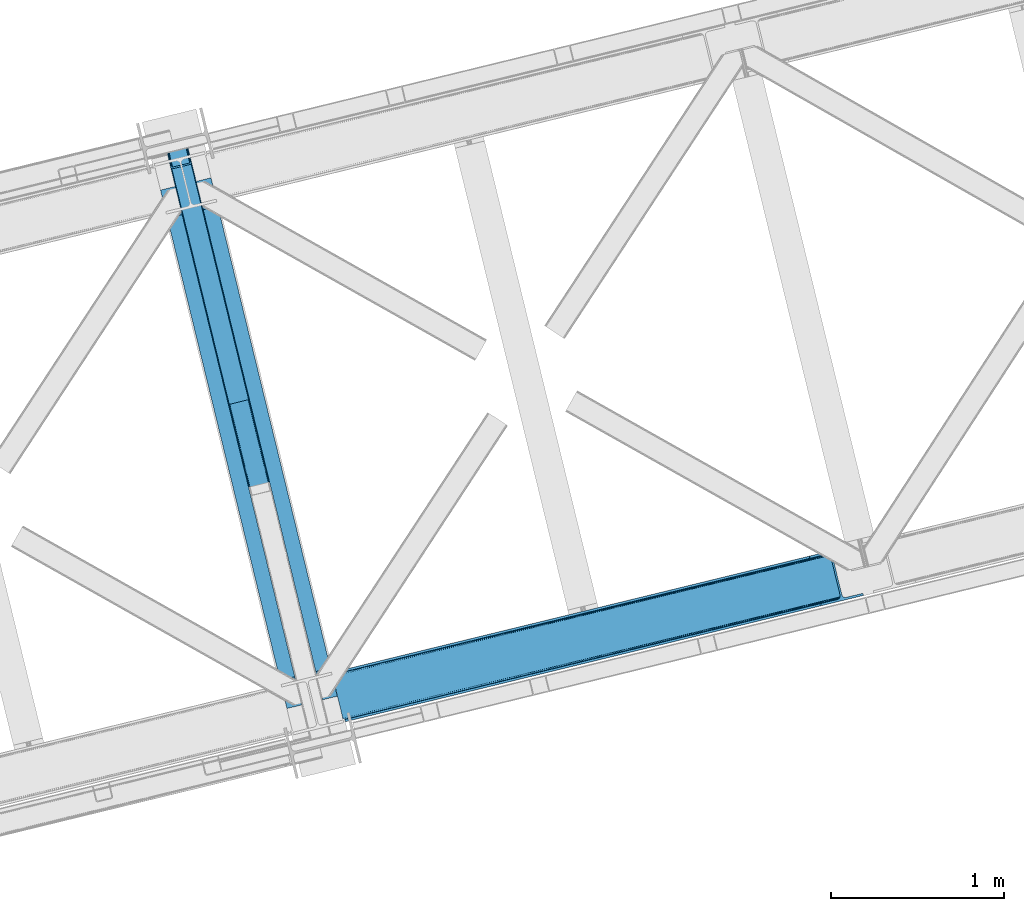
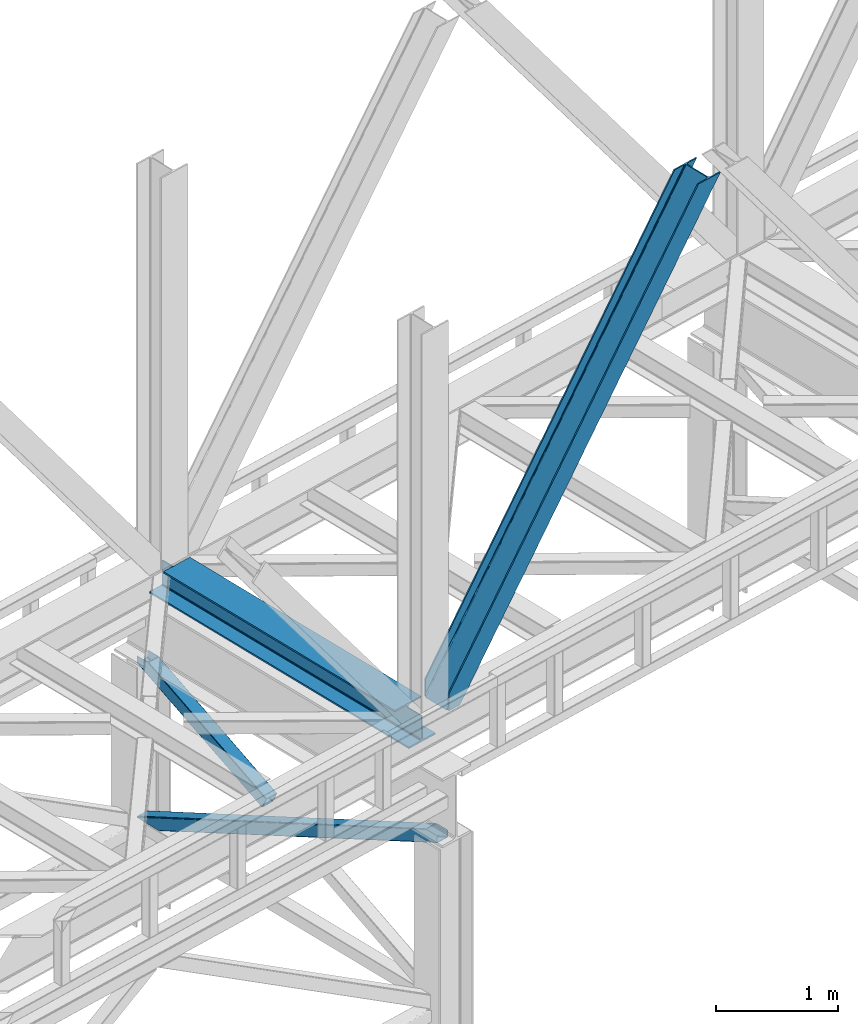
# One storey, part 51 of 93: 3 members, 1 beam.
"""IFC4 building model written with IfcOpenShell, lengths in millimetres."""

import ifcopenshell
import ifcopenshell.guid

model = None  # the IFC model being written
_history = None  # IfcOwnerHistory: only IFC2X3 demands one
_inside = {}  # id of a spatial element -> (the spatial element, [elements in it])
_under = {}  # id of a project, library or spatial element -> (it, [spatial elements below it])
_declared = {}  # id of a project -> (the project, [libraries it declares])
_typed = {}  # id of a type object -> (the type object, [elements of that type])
_made_of = {}  # id of a material, layer set ... -> (it, [elements and type objects made of it])


def new_model(schema):
    """Start an empty IFC model of exactly this schema.

    Asked for "IFC4X3", IfcOpenShell would pick the latest addendum, in which some entities
    have other attributes; the version numbers below select the first issue.
    IFC2X3 requires an IfcOwnerHistory on every rooted entity: one is made here for all.
    """
    global model, _history
    if schema == "IFC4X3":
        model = ifcopenshell.file(schema_version=(4, 3, 0, 0))
    else:
        model = ifcopenshell.file(schema=schema)
    _inside.clear()
    _under.clear()
    _declared.clear()
    _typed.clear()
    _made_of.clear()
    _history = None
    if model.schema == "IFC2X3":
        org = make("IfcOrganization", Name="unknown")
        user = make(
            "IfcPersonAndOrganization",
            ThePerson=make("IfcPerson", FamilyName="unknown"),
            TheOrganization=org,
        )
        app = make(
            "IfcApplication",
            ApplicationDeveloper=org,
            Version="unknown",
            ApplicationFullName="unknown",
            ApplicationIdentifier="unknown",
        )
        _history = make(
            "IfcOwnerHistory",
            OwningUser=user,
            OwningApplication=app,
            ChangeAction="ADDED",
            CreationDate=0,
        )
    return model


def make(cls, **values):
    """One entity of the class cls with the attributes given. An attribute that is None is left unset."""
    return model.create_entity(
        cls, **{name: value for name, value in values.items() if value is not None}
    )


def entity(cls, *values):
    """Any entity or typed value of the class cls, its attributes in the order of the schema. None: left unset."""
    e = model.create_entity(cls)
    for i, value in enumerate(values):
        if value is not None:
            e[i] = value
    return e


def rooted(cls, **values):
    """An entity with a GlobalId (a new one), such as an element, a storey or a relation."""
    return make(cls, GlobalId=ifcopenshell.guid.new(), OwnerHistory=_history, **values)


def si_unit(unit_type, name, prefix=None):
    """IfcSIUnit, for example si_unit("LENGTHUNIT", "METRE", prefix="MILLI")."""
    return make("IfcSIUnit", UnitType=unit_type, Prefix=prefix, Name=name)


def converted_unit(unit_type, name, factor, base, dimensions=None, offset=None):
    """IfcConversionBasedUnit, such as the inch: factor (a typed value) times the base unit."""
    return make(
        "IfcConversionBasedUnit"
        if offset is None
        else "IfcConversionBasedUnitWithOffset",
        ConversionOffset=offset,
        Dimensions=None
        if dimensions is None
        else entity("IfcDimensionalExponents", *dimensions),
        UnitType=unit_type,
        Name=name,
        ConversionFactor=make(
            "IfcMeasureWithUnit", ValueComponent=factor, UnitComponent=base
        ),
    )


def derived_unit(unit_type, elements):
    """IfcDerivedUnit: a product of units, each with its exponent."""
    return make(
        "IfcDerivedUnit",
        Elements=[
            make("IfcDerivedUnitElement", Unit=unit, Exponent=power)
            for unit, power in elements
        ],
        UnitType=unit_type,
    )


def assignment(units):
    """IfcUnitAssignment: the units of a project."""
    return None if units is None else make("IfcUnitAssignment", Units=units)


def point(xyz):
    """IfcCartesianPoint."""
    return None if xyz is None else make("IfcCartesianPoint", Coordinates=xyz)


def direction(xyz):
    """IfcDirection."""
    return None if xyz is None else make("IfcDirection", DirectionRatios=xyz)


def frame(location, z_axis=None, x_axis=None):
    """IfcAxis2Placement3D, a coordinate frame: its origin and axes. An axis left out is left unset."""
    return make(
        "IfcAxis2Placement3D",
        Location=point(location),
        Axis=direction(z_axis),
        RefDirection=direction(x_axis),
    )


def origin():
    """The frame at (0, 0, 0) with its axes left unset."""
    return frame((0.0, 0.0, 0.0))


def place(relative_to, where):
    """IfcLocalPlacement: puts the frame where relative to a parent placement (None: the world)."""
    return make(
        "IfcLocalPlacement", PlacementRelTo=relative_to, RelativePlacement=where
    )


def context(
    kind, dimensions, precision=None, world=None, true_north=None, identifier=None
):
    """IfcGeometricRepresentationContext, for example the 3D "Model" context."""
    return make(
        "IfcGeometricRepresentationContext",
        ContextIdentifier=identifier,
        ContextType=kind,
        CoordinateSpaceDimension=dimensions,
        Precision=precision,
        WorldCoordinateSystem=world,
        TrueNorth=true_north,
    )


def subcontext(parent, identifier, kind, view, scale=None):
    """IfcGeometricRepresentationSubContext, for example "Body" below "Model"."""
    return make(
        "IfcGeometricRepresentationSubContext",
        ContextIdentifier=identifier,
        ContextType=kind,
        ParentContext=parent,
        TargetScale=scale,
        TargetView=view,
    )


def project(units=None, contexts=None):
    """IfcProject with its units and contexts."""
    return rooted(
        "IfcProject",
        Name="project",
        RepresentationContexts=contexts,
        UnitsInContext=assignment(units),
    )


def spatial(cls, under=None, at=None, **own):
    """A site, building, storey or space (cls), placed at a placement, below another one or the project."""
    s = rooted(cls, ObjectPlacement=at, **own)
    if under is not None:
        _under.setdefault(under.id(), (under, []))[1].append(s)
    return s


def point_list(points):
    """IfcCartesianPointList2D or 3D."""
    cls = (
        "IfcCartesianPointList2D" if len(points[0]) == 2 else "IfcCartesianPointList3D"
    )
    return make(cls, CoordList=points)


def triangles(points, corners, closed=None, point_numbers=None):
    """IfcTriangulatedFaceSet: each triangle names its three corners, points numbered from 1."""
    return make(
        "IfcTriangulatedFaceSet",
        Coordinates=point_list(points),
        Closed=closed,
        CoordIndex=corners,
        PnIndex=point_numbers,
    )


def polygons(points, faces, closed=None, point_numbers=None):
    """IfcPolygonalFaceSet: a face is its outer loop, then its inner loops; points numbered from 1."""
    made = []
    for loops in faces:
        if len(loops) == 1:
            made.append(make("IfcIndexedPolygonalFace", CoordIndex=loops[0]))
        else:
            made.append(
                make(
                    "IfcIndexedPolygonalFaceWithVoids",
                    CoordIndex=loops[0],
                    InnerCoordIndices=loops[1:],
                )
            )
    return make(
        "IfcPolygonalFaceSet",
        Coordinates=point_list(points),
        Closed=closed,
        Faces=made,
        PnIndex=point_numbers,
    )


def shape(context_of_items, identifier, shape_type, items):
    """IfcShapeRepresentation: the items that make up one representation, for example the "Body"."""
    return make(
        "IfcShapeRepresentation",
        ContextOfItems=context_of_items,
        RepresentationIdentifier=identifier,
        RepresentationType=shape_type,
        Items=items,
    )


def material(Name=None, Category=None):
    """IfcMaterial."""
    return make("IfcMaterial", Name=Name, Category=Category)


def made_of(thing, what):
    """Note that an element or type object is made of a material, layer set ...; save() writes the relation."""
    if what is not None:
        _made_of.setdefault(what.id(), (what, []))[1].append(thing)
    return thing


def type_object(cls, material=None, **own):
    """A type object (cls), such as IfcWallType, which elements share."""
    return made_of(rooted(cls, **own), material)


def element(
    cls,
    number,
    at=None,
    inside=None,
    cuts=None,
    type_object=None,
    material=None,
    context=None,
    identifier="Body",
    shape_type=None,
    held_by="IfcProductDefinitionShape",
    body=None,
    shapes=None,
    **own,
):
    """One element of the class cls, such as IfcWall. Its Tag is "e" and its number.

    at: its placement. inside: the storey or other place that contains it. cuts: it is an
    opening in that element (IfcRelVoidsElement). A single representation is given by context,
    identifier, shape_type and body (its items); several are given by shapes. held_by: the class
    of the entity that holds the representations. save() writes the other relations.
    """
    e = rooted(cls, Tag="e%d" % number, ObjectPlacement=at, **own)
    if body is not None:
        shapes = [shape(context, identifier, shape_type, body)]
    if shapes is not None:
        e.Representation = make(held_by, Representations=shapes)
    if inside is not None:
        _inside.setdefault(inside.id(), (inside, []))[1].append(e)
    if cuts is not None:
        rooted(
            "IfcRelVoidsElement", RelatingBuildingElement=cuts, RelatedOpeningElement=e
        )
    if type_object is not None:
        _typed.setdefault(type_object.id(), (type_object, []))[1].append(e)
    return made_of(e, material)


def aggregate(whole, parts):
    """IfcRelAggregates: a whole, such as a stair, and the parts it consists of."""
    return rooted("IfcRelAggregates", RelatingObject=whole, RelatedObjects=parts)


def save(model, path):
    """Write the relations noted so far, then the file.

    IfcRelAggregates (storeys below a building ...), IfcRelContainedInSpatialStructure (elements
    in a storey), IfcRelDefinesByType, IfcRelAssociatesMaterial and IfcRelDeclares: one each for
    every whole, place, type object, material and project.
    """
    for whole, parts in _under.values():
        aggregate(whole, parts)
    for where, things in _inside.values():
        rooted(
            "IfcRelContainedInSpatialStructure",
            RelatedElements=things,
            RelatingStructure=where,
        )
    for kind, things in _typed.values():
        rooted("IfcRelDefinesByType", RelatedObjects=things, RelatingType=kind)
    for what, things in _made_of.values():
        rooted("IfcRelAssociatesMaterial", RelatedObjects=things, RelatingMaterial=what)
    for by, libraries in _declared.values():
        rooted("IfcRelDeclares", RelatingContext=by, RelatedDefinitions=libraries)
    model.write(path)


model = new_model("IFC4")

# Units and contexts
model_context = context("Model", 3, precision=0.01, world=origin(), true_north=direction((6.12303176911189e-17, 1.0)))
plan_context = context("Plan", 3, precision=0.01, world=origin(), true_north=direction((6.12303176911189e-17, 1.0)))
body_context = subcontext(model_context, "Body", "Model", "MODEL_VIEW")
ifc_project = project(units=[si_unit("LENGTHUNIT", "METRE", prefix="MILLI"), si_unit("AREAUNIT", "SQUARE_METRE"), si_unit("VOLUMEUNIT", "CUBIC_METRE"), converted_unit("PLANEANGLEUNIT", "DEGREE", entity("IfcRatioMeasure", 0.0174532925199433), si_unit("PLANEANGLEUNIT", "RADIAN"), dimensions=[0, 0, 0, 0, 0, 0, 0]), si_unit("MASSUNIT", "GRAM", prefix="KILO"), derived_unit("MASSDENSITYUNIT", [(si_unit("MASSUNIT", "GRAM", prefix="KILO"), 1), (si_unit("LENGTHUNIT", "METRE"), -3)]), derived_unit("MOMENTOFINERTIAUNIT", [(si_unit("LENGTHUNIT", "METRE"), 4)]), si_unit("TIMEUNIT", "SECOND"), si_unit("FREQUENCYUNIT", "HERTZ"), si_unit("THERMODYNAMICTEMPERATUREUNIT", "DEGREE_CELSIUS"), derived_unit("THERMALTRANSMITTANCEUNIT", [(si_unit("MASSUNIT", "GRAM", prefix="KILO"), 1), (si_unit("THERMODYNAMICTEMPERATUREUNIT", "KELVIN"), -1), (si_unit("TIMEUNIT", "SECOND"), -3)]), derived_unit("VOLUMETRICFLOWRATEUNIT", [(si_unit("LENGTHUNIT", "METRE"), 3), (si_unit("TIMEUNIT", "SECOND"), -1)]), derived_unit("MASSFLOWRATEUNIT", [(si_unit("MASSUNIT", "GRAM", prefix="KILO"), 1), (si_unit("TIMEUNIT", "SECOND"), -1)]), derived_unit("ROTATIONALFREQUENCYUNIT", [(si_unit("TIMEUNIT", "SECOND"), -1)]), si_unit("ELECTRICCURRENTUNIT", "AMPERE"), si_unit("ELECTRICVOLTAGEUNIT", "VOLT"), si_unit("POWERUNIT", "WATT"), si_unit("FORCEUNIT", "NEWTON", prefix="KILO"), si_unit("ILLUMINANCEUNIT", "LUX"), si_unit("LUMINOUSFLUXUNIT", "LUMEN"), si_unit("LUMINOUSINTENSITYUNIT", "CANDELA"), derived_unit("USERDEFINED", [(si_unit("MASSUNIT", "GRAM", prefix="KILO"), -1), (si_unit("LENGTHUNIT", "METRE"), -2), (si_unit("TIMEUNIT", "SECOND"), 3), (si_unit("LUMINOUSFLUXUNIT", "LUMEN"), 1)]), derived_unit("LINEARVELOCITYUNIT", [(si_unit("LENGTHUNIT", "METRE"), 1), (si_unit("TIMEUNIT", "SECOND"), -1)]), si_unit("PRESSUREUNIT", "PASCAL"), derived_unit("USERDEFINED", [(si_unit("LENGTHUNIT", "METRE"), -2), (si_unit("MASSUNIT", "GRAM", prefix="KILO"), 1), (si_unit("TIMEUNIT", "SECOND"), -2)]), derived_unit("LINEARFORCEUNIT", [(si_unit("MASSUNIT", "GRAM", prefix="KILO"), 1), (si_unit("LENGTHUNIT", "METRE"), 1), (si_unit("TIMEUNIT", "SECOND"), -2), (si_unit("LENGTHUNIT", "METRE"), -1)]), derived_unit("PLANARFORCEUNIT", [(si_unit("MASSUNIT", "GRAM", prefix="KILO"), 1), (si_unit("LENGTHUNIT", "METRE"), 1), (si_unit("TIMEUNIT", "SECOND"), -2), (si_unit("LENGTHUNIT", "METRE"), -2)])], contexts=[model_context, plan_context])

# Site, building, storey
site_placement = place(None, origin())
site = spatial("IfcSite", under=ifc_project, at=site_placement, CompositionType="ELEMENT")
building_placement = place(site_placement, origin())
building = spatial("IfcBuilding", under=site, at=building_placement, CompositionType="ELEMENT")
storey_placement = place(building_placement, frame((0.0, 0.0, 15900.0)))
storey = spatial("IfcBuildingStorey", under=building, at=storey_placement, CompositionType="ELEMENT", Elevation=15900.0)

# Beam
ifc_material = material(Name="Metal painted (White)")
beam_type = type_object("IfcBeamType", PredefinedType="BEAM")
beam_placement = place(storey_placement, frame((-36670.8270654766, 8847.80273700045, 3385.0)))
element("IfcBeam", 1, at=beam_placement, inside=storey, type_object=beam_type, material=ifc_material, ObjectType="Steel Beam", PredefinedType="BEAM", context=body_context, shape_type="Tessellation", body=[
    polygons([(1022.42935345712, 71.0478278971032, 15.4999999999986), (1022.42935345712, 71.047827897101, 0.0), (291.465617442442, 3069.74325535076, 0.0), (291.465617442442, 3069.74325535076, 15.4999999999986), (899.042242073157, 40.970914087328, 15.4999999999986), (168.078506058478, 3039.66634154099, 15.4999999999986), (892.349898299203, 39.3395844888254, 16.8701684147963), (161.386162284524, 3038.03501194248, 16.8701684147963), (886.676403198579, 37.9566100336519, 20.7720779386413), (155.7126671839, 3036.65203748731, 20.7720779386413), (882.88549497, 37.0325360459162, 26.6116982174294), (151.921758955325, 3035.72796349958, 26.6116982174294), (881.554305026607, 36.7080444135029, 33.500000000001), (150.590569011932, 3035.40347186716, 33.500000000001), (140.875048430518, 3033.03521093726, 33.500000000001), (140.875048430518, 3033.03521093726, 259.000000000002), (150.590569011932, 3035.40347186716, 259.000000000002), (4.33146851719357e-12, 2998.69542745366, 0.0), (4.33146851719357e-12, 2998.69542745366, 15.4999999999986), (123.387111383964, 3028.77234126343, 15.4999999999986), (130.079455157922, 3030.40367086194, 16.8701684147963), (135.752950258542, 3031.78664531711, 20.7720779386413), (139.543858487117, 3032.71071930484, 26.6116982174294), (881.554305026612, 36.7080444135018, 259.000000000002), (871.838784445197, 34.3397834835992, 259.000000000002), (871.838784445197, 34.3397834835981, 33.500000000001), (870.507594501796, 34.0152918511827, 26.6116982174294), (866.716686273221, 33.0912178634492, 20.7720779386413), (861.043191172601, 31.7082434082767, 16.8701684147963), (854.350847398639, 30.0769138097708, 15.4999999999986), (730.963736014684, 1.08286712929839e-12, 15.4999999999986), (730.963736014675, 1.08286712929839e-12, 0.0), (841.854534586248, 199.571930111232, 259.069791776412), (190.199733064572, 2872.911390143, 259.000000000002), (190.423126166417, 2871.99494573803, 259.61730333112), (190.435515010051, 2871.94412150426, 266.500003008253), (841.709355772749, 200.167408132524, 266.500002998871), (841.709705893497, 200.16597182779, 260.000004007589), (832.229597305449, 196.831858094286, 259.006343172366), (832.006227290708, 197.748309612731, 259.61730333112), (831.993838447078, 197.799133846506, 266.500003008253), (180.719997684385, 2869.57584721824, 266.500002998871), (180.719647563629, 2869.57728352297, 260.000004007589), (180.574841905293, 2870.17133233676, 259.07612046749), (180.484212483149, 2870.5431292131, 259.000000000002), (843.040843642663, 200.490677577209, 273.388305639783), (846.831120231363, 201.417342749122, 279.227924098781), (852.504191178897, 202.8020572128, 283.129832400619), (859.196382860031, 204.434010743613, 284.500000377228), (982.583411547866, 234.511263798723, 284.500000138971), (982.581741741215, 234.518113867454, 299.999995328161), (691.116319643944, 163.469484603412, 299.999995890962), (691.117989450605, 163.462634534681, 284.500000701776), (814.50501813844, 193.539887589791, 284.500000463519), (821.197505034579, 195.170630056369, 283.129832461069), (826.871416683348, 196.551895700895, 279.227924137322), (830.662951470335, 197.473399350192, 273.388305663684), (179.388509814454, 2869.25257777355, 273.388305639783), (175.598233225758, 2868.32591260164, 279.227924098781), (169.925162278228, 2866.94119813796, 283.129832400619), (163.232970597094, 2865.30924460715, 284.500000377228), (39.8459419092591, 2835.23199155204, 284.500000138971), (39.8476117159108, 2835.22514148331, 299.999995328161), (331.313033813177, 2906.27377074735, 299.999995890962), (331.311364006521, 2906.28062081608, 284.500000701776), (207.924335318677, 2876.20336776097, 284.500000463519), (201.231848422542, 2874.57262529439, 283.129832461069), (195.557936773782, 2873.19135964986, 279.227924137322), (191.766401986782, 2872.26985600057, 273.388305663684)], [[[1, 2, 3, 4]], [[5, 1, 4, 6]], [[7, 5, 6, 8]], [[9, 7, 8, 10]], [[11, 9, 10, 12]], [[13, 11, 12, 14]], [[15, 16, 17, 14, 12, 10, 8, 6, 4, 3, 18, 19, 20, 21, 22, 23]], [[13, 24, 25, 26, 27, 28, 29, 30, 31, 32, 2, 1, 5, 7, 9, 11]], [[2, 32, 18, 3]], [[32, 31, 19, 18]], [[31, 30, 20, 19]], [[27, 26, 15, 23]], [[28, 27, 23, 22]], [[29, 28, 22, 21]], [[30, 29, 21, 20]], [[33, 24, 13, 14, 17, 34, 35, 36, 37, 38]], [[25, 39, 40, 41, 42, 43, 44, 16, 15, 26]], [[39, 25, 24, 33]], [[45, 34, 17, 16]], [[41, 40, 38, 37, 46, 47, 48, 49, 50, 51, 52, 53, 54, 55, 56, 57]], [[42, 58, 59, 60, 61, 62, 63, 64, 65, 66, 67, 68, 69, 36, 35, 43]], [[46, 37, 36, 69]], [[47, 46, 69, 68]], [[48, 47, 68, 67]], [[49, 48, 67, 66]], [[50, 49, 66, 65]], [[51, 50, 65, 64]], [[52, 51, 64, 63]], [[53, 52, 63, 62]], [[54, 53, 62, 61]], [[55, 54, 61, 60]], [[56, 55, 60, 59]], [[57, 56, 59, 58]], [[41, 57, 58, 42]]], closed=False),
])

# Members
member_type_1 = type_object("IfcMemberType", PredefinedType="BRACE")
member_1_placement = place(storey_placement, frame((-35677.0246398926, 8771.3582107544, 3694.99929199219)))
element("IfcMember", 2, at=member_1_placement, inside=storey, type_object=member_type_1, ObjectType="Steel Vertical Brace", PredefinedType="BRACE", context=body_context, shape_type="Tessellation", body=[
    triangles([(58.5289855957017, 27.9221328735348, 0.0), (60.4567749023481, 20.0173828124989, 0.0), (59.0987182617173, 20.9713943481438, 0.827856445310317), (58.9708190917954, 19.7935592651356, 1.13481445312209), (72.0374633789106, 11.6585906982418, 0.0), (71.2235595703169, 13.9003143310547, 30.2981506347642), (70.081768798831, 15.4002227783203, 25.0194030761704), (72.0374633789106, 11.6585906982418, 170.803527832031), (71.7537597656265, 12.6189971923832, 41.9881347656228), (71.7537597656265, 12.6189971923832, 170.743066406249), (70.2445495605498, 15.5234710693348, 0.0), (68.6446472167954, 17.2873168945316, 18.377947998044), (66.9517272949233, 18.0907562255852, 14.9735046386704), (67.1191589355512, 18.4180618286136, 0.0), (63.1287048339873, 19.9086685180664, 7.26932373046657), (63.1287048339873, 19.9086685180664, 0.0), (2824.67409667969, 683.67222290039, 3911.00081176758), (2919.44040527344, 706.773138427734, 3911.00081176758), (2937.07886352539, 722.50938720703, 3911.00081176758), (2933.70465087891, 715.676664733886, 3911.00081176758), (2937.11839599609, 729.608953857422, 3911.00081176758), (2927.51200561524, 710.150839233398, 3911.00081176758), (2827.75297851563, 671.042179870605, 3911.00081176758), (74.879150390625, 0.0, 170.803527832031), (74.879150390625, 0.0, 0.0), (192.937060546879, 28.7778945922855, 0.0), (3071.52647094727, 730.464715576172, 3911.00081176758), (3068.44758911133, 743.094758605957, 3911.00081176758), (189.858178710936, 41.4085189819325, 0.0), (2973.67895507813, 719.994424438477, 3911.00081176758), (95.0918701171904, 18.308184814452, 0.0), (2964.96088256836, 719.278770446777, 3911.00081176758), (86.3714721679717, 17.5925308227543, 0.0), (2956.91951293945, 721.335040283202, 3911.00081176758), (78.330102539061, 19.6482192993153, 0.0), (2950.77802734375, 725.848718261719, 3911.00081176758), (72.190942382811, 24.1624786376942, 0.0), (2947.47822875977, 732.134381103515, 3911.00081176758), (68.8888183593735, 30.4481414794918, 0.0), (2892.29787597656, 958.506028747559, 3911.00081176758), (13.7084655761719, 256.819789123534, 0.0), (2892.33508300781, 965.605014038085, 3911.00081176758), (13.7479980468779, 263.918774414062, 0.0), (2895.7092956543, 972.438317871094, 3911.00081176758), (17.1198852539092, 270.751496887207, 0.0), (2901.90194091797, 977.964143371582, 3911.00081176758), (23.3125305175781, 276.277322387696, 0.0), (2909.97354125977, 981.341844177246, 3911.00081176758), (31.386456298831, 279.655604553222, 0.0), (3004.74217529297, 1004.44275970459, 3911.00081176758), (126.152764892577, 302.755938720702, 0.0), (3001.66329345703, 1017.07222137451, 3911.00081176758), (123.073883056641, 315.385981750487, 0.0), (2881.93804321289, 955.980601501464, 3911.00081176758), (3.3486328125, 254.293780517577, 0.0), (2872.4967590332, 966.779942321777, 3911.00081176758), (2864.4553894043, 968.835630798339, 3911.00081176758), (2757.88747558594, 957.650267028808, 3911.00081176758), (2855.73499145508, 968.120558166504, 3911.00081176758), (2760.96635742188, 945.019642639159, 3911.00081176758), (2878.63359375, 962.265682983398, 3911.00081176758), (5.01364746093896, 286.608087158203, 170.803527832031), (5.01364746093896, 286.608087158203, 0.0), (7.85533447266062, 274.94949645996, 170.803527832031), (8.04834594726708, 273.966416931153, 170.743066406249), (8.04834594726708, 273.966416931153, 41.9881347656228), (7.85533447266062, 274.94949645996, 0.0), (3.74628295898583, 263.525775146483, 0.0), (6.60192260742042, 266.684884643555, 0.0), (8.04369506835792, 270.693360900879, 0.0), (1.42084350586083, 262.199111938477, 0.0), (3.74628295898583, 263.525775146483, 7.26932373046657), (6.30194091796875, 266.898825073242, 14.9735046386704), (7.43442993164354, 268.390594482422, 18.377947998044), (8.16694335937791, 272.585105895996, 30.2981506347642), (7.84138183594041, 270.727079772949, 25.0194030761704), (0.0, 261.714839172362, 1.13481445312209), (0.65577392578416, 260.727690124511, 0.827856445310317)], [[1, 2, 3], [4, 3, 2], [5, 6, 7], [5, 8, 9], [10, 9, 8], [9, 6, 5], [11, 12, 13], [11, 7, 12], [14, 13, 15], [15, 4, 2], [2, 16, 15], [15, 16, 14], [13, 14, 11], [7, 11, 5], [17, 18, 10], [9, 10, 18], [19, 3, 15], [15, 20, 19], [12, 20, 13], [15, 13, 20], [3, 4, 15], [19, 21, 1], [1, 3, 19], [6, 20, 7], [6, 22, 20], [12, 7, 20], [18, 22, 9], [6, 9, 22], [8, 17, 10], [23, 8, 24], [8, 23, 17], [25, 24, 5], [8, 5, 24], [23, 26, 27], [26, 23, 24], [25, 26, 24], [28, 27, 29], [26, 29, 27], [30, 28, 29], [29, 31, 30], [32, 30, 31], [31, 33, 32], [34, 32, 33], [33, 35, 34], [36, 34, 35], [35, 37, 36], [38, 36, 37], [37, 39, 38], [40, 38, 41], [39, 41, 38], [42, 40, 43], [41, 43, 40], [44, 42, 45], [43, 45, 42], [46, 44, 47], [45, 47, 44], [48, 46, 49], [47, 49, 46], [50, 48, 51], [49, 51, 48], [52, 50, 51], [51, 53, 52], [21, 54, 1], [55, 1, 54], [54, 21, 38], [20, 22, 32], [18, 23, 27], [17, 23, 18], [22, 18, 30], [21, 19, 36], [19, 20, 34], [56, 46, 57], [58, 59, 52], [59, 57, 48], [58, 60, 59], [56, 61, 44], [61, 54, 42], [40, 54, 38], [30, 32, 22], [36, 19, 34], [32, 34, 20], [36, 38, 21], [27, 30, 18], [27, 28, 30], [48, 57, 46], [44, 61, 42], [40, 42, 54], [44, 46, 56], [48, 52, 59], [52, 48, 50], [58, 53, 62], [58, 52, 53], [53, 63, 62], [64, 58, 62], [60, 64, 65], [64, 60, 58], [59, 60, 65], [65, 66, 59], [67, 64, 62], [62, 63, 67], [11, 35, 5], [68, 41, 55], [69, 70, 43], [69, 43, 68], [55, 71, 68], [67, 63, 47], [67, 45, 70], [55, 39, 1], [37, 14, 16], [2, 1, 16], [16, 1, 39], [11, 14, 37], [25, 5, 33], [39, 55, 41], [49, 47, 63], [43, 70, 45], [47, 45, 67], [43, 41, 68], [53, 49, 63], [53, 51, 49], [31, 25, 33], [35, 11, 37], [39, 37, 16], [35, 33, 5], [31, 26, 25], [26, 31, 29], [72, 68, 71], [69, 68, 72], [70, 69, 73], [73, 74, 70], [67, 75, 66], [67, 70, 76], [76, 75, 67], [64, 67, 66], [66, 65, 64], [74, 76, 70], [72, 73, 69], [71, 77, 72], [78, 61, 72], [61, 56, 74], [74, 73, 61], [73, 72, 61], [57, 59, 66], [66, 75, 57], [56, 75, 76], [75, 56, 57], [76, 74, 56], [72, 77, 78], [54, 61, 55], [78, 55, 61], [71, 55, 78], [78, 77, 71]]),
])
member_type_2 = type_object("IfcMemberType", PredefinedType="BRACE")
member_2_placement = place(storey_placement, frame((-36642.8913487998, 10607.3296947794, 1820.90870290301)))
element("IfcMember", 3, at=member_2_placement, inside=storey, type_object=member_type_2, ObjectType="Steel Vertical Brace", PredefinedType="BRACE", context=body_context, shape_type="Tessellation", body=[
    polygons([(29.8135191782847, 1388.61826467864, 771.091297096984), (32.1113287327985, 1381.7631169139, 771.091297096989), (368.111452939622, 3.36089743274203, 105.060837153748), (367.211709770163, 4.48063717440627, 102.289544138114), (35.2425975620341, 1376.24004026086, 771.091297096982), (370.057498317433, 2.70006492288447, 107.410225929579), (38.7306183717297, 1372.88987307312, 771.091297096989), (372.75357813572, 2.59874540396945, 108.980037321763), (42.0443716126254, 1372.22264793569, 771.091297096984), (375.789238682203, 3.07236385431241, 109.531281776207), (140.171129484908, 1396.14208332771, 771.091297096984), (473.915996554486, 26.9917992463345, 109.531281776209), (142.806126265313, 1398.25937921937, 771.091297096991), (476.829086029299, 27.9682515502176, 108.980037321767), (144.361212211713, 1402.83885703392, 771.091297096984), (479.176112967108, 29.2988816959484, 107.410225929583), (144.599639585688, 1409.18333278718, 771.091297096997), (480.599763792516, 30.7811133060222, 105.060837153757), (143.485109980843, 1416.32691755851, 771.091297096984), (480.883300572716, 32.1892900542756, 102.289544138114), (149.600536198011, 1408.12910918704, 771.09129709698), (121.44400726769, 1523.63806044727, 771.091297096982), (117.557799035115, 1522.69075607531, 771.09129709698), (3.88620823256572, 1494.98210319544, 771.091297096982), (4.33146851719357e-12, 1494.03479882348, 771.091297096982), (28.1565289303171, 1378.52584756325, 771.09129709698), (30.4543384848309, 1371.67069979849, 771.091297096982), (33.5856073140622, 1366.14762314544, 771.091297096982), (37.0736281237621, 1362.79745595771, 771.091297096984), (40.3873813646535, 1362.13023082029, 771.09129709698), (146.286555702072, 1387.94427495624, 771.09129709698), (148.921552482481, 1390.06157084789, 771.091297096984), (150.476638428881, 1394.64104866244, 771.09129709698), (150.715065802839, 1400.98552441569, 771.09129709698), (359.725704690142, 52.0811507006333, 4.33146851719357e-12), (465.62487902756, 77.8951948365801, 2.16573425859679e-12), (468.660539574047, 78.3688132869209, 0.551244454446396), (471.356619392343, 78.2674937680102, 2.12105584662818), (473.302664770137, 77.6066612581418, 4.4704446224671), (474.202407939605, 76.4869215164841, 7.24173763810153), (485.172065028735, 31.4851533942308, 105.910412957166), (484.888528248512, 30.0769766459796, 108.681705972796), (483.46487742313, 28.5947450359037, 111.031094748631), (481.117850485317, 27.2641148901728, 112.600906140819), (478.204761010504, 26.2876625862876, 113.152150595261), (372.305586673086, 0.473618450342957, 113.152150595257), (369.269926126603, 2.16573425859679e-12, 112.600906140819), (366.573846308307, 0.101319518910685, 111.031094748635), (364.627800930509, 0.76215202877691, 108.681705972796), (363.728057761045, 1.88189177043682, 105.910412957166), (352.758400671911, 46.8836598926901, 7.24173763810153), (353.041937452142, 48.2918366409434, 4.4704446224671), (354.465588277524, 49.7740682510194, 2.12105584662385), (356.812615215332, 51.1046983967459, 0.551244454448562), (470.718755930487, 73.8881761125124, 10.8626064571491), (469.819012761023, 75.0079158541724, 8.09131344151462), (467.872967383238, 75.6687483640429, 5.74192466567137), (465.176887564938, 75.7700678829471, 4.17211327349608), (462.141227018446, 75.2964494326085, 3.62086881905185), (364.01446914616, 51.3770140405842, 3.62086881905185), (361.101379671355, 50.4005617366968, 4.17211327349392), (358.754352733542, 49.0699315909703, 5.74192466567787), (357.33070190816, 47.5876999808965, 8.09131344151462), (357.047165127938, 46.1795232326431, 10.8626064571491), (3.88620823256572, 1494.98210319544, 710.909831470177), (117.557799035128, 1522.69075607531, 710.909831470175), (11.6586246977015, 1496.87671193936, 702.072173549059), (8.91066050334255, 1496.2068665941, 703.366418586696), (6.16269630900526, 1495.53702124884, 704.660663624354), (5.02445227078982, 1495.25956222214, 707.785247547264), (116.4195549969, 1522.41329704861, 707.785247547264), (115.281310958689, 1522.13583802191, 704.660663624352), (112.533346764343, 1521.46599267665, 703.3664185867), (109.785382569988, 1520.79614733139, 702.072173549057), (120.30576322947, 1523.36060142057, 703.366418586702), (119.167519191254, 1523.08314239387, 700.241834663787), (116.419554996904, 1522.41329704861, 698.94758962614), (113.671590802554, 1521.74345170335, 697.653344588497), (7.77241646513577, 1495.9294075674, 697.653344588497), (5.02445227078549, 1495.25956222214, 698.947589626138), (2.27648807643955, 1494.58971687688, 700.241834663785), (1.13824403821544, 1494.31225785018, 703.366418586702), (4.33146851719357e-12, 1494.03479882348, 706.491002509615), (121.44400726769, 1523.63806044727, 706.491002509615)], [[[1, 2, 3, 4]], [[2, 5, 6, 3]], [[5, 7, 8, 6]], [[7, 9, 10, 8]], [[9, 11, 12, 10]], [[11, 13, 14, 12]], [[13, 15, 16, 14]], [[15, 17, 18, 16]], [[17, 19, 20, 18]], [[21, 22, 23, 19, 17, 15, 13, 11, 9, 7, 5, 2, 1, 24, 25, 26, 27, 28, 29, 30, 31, 32, 33, 34]], [[35, 36, 37, 38, 39, 40, 41, 42, 43, 44, 45, 46, 47, 48, 49, 50, 51, 52, 53, 54], [55, 56, 57, 58, 59, 60, 61, 62, 63, 64, 4, 3, 6, 8, 10, 12, 14, 16, 18, 20]], [[24, 1, 4, 64, 65]], [[19, 23, 66, 55, 20]], [[61, 67, 68]], [[62, 68, 69]], [[63, 69, 70]], [[64, 70, 65]], [[70, 64, 63]], [[69, 63, 62]], [[68, 62, 61]], [[67, 61, 60]], [[55, 71, 56]], [[56, 72, 57]], [[57, 73, 58]], [[58, 74, 59]], [[74, 58, 73]], [[73, 57, 72]], [[72, 56, 71]], [[71, 55, 66]], [[74, 67, 60, 59]], [[75, 76, 77, 78, 79, 80, 81, 82, 83, 25, 24, 65, 70, 69, 68, 67, 74, 73, 72, 71, 66, 23, 22, 84]], [[30, 29, 47, 46]], [[29, 28, 48, 47]], [[28, 27, 49, 48]], [[27, 26, 50, 49]], [[45, 31, 30, 46]], [[21, 34, 42, 41]], [[34, 33, 43, 42]], [[33, 32, 44, 43]], [[32, 31, 45, 44]], [[50, 26, 25, 83, 51]], [[84, 22, 21, 41, 40]], [[51, 82, 52]], [[52, 81, 53]], [[53, 80, 54]], [[54, 79, 35]], [[79, 54, 80]], [[80, 53, 81]], [[81, 52, 82]], [[82, 51, 83]], [[37, 78, 77]], [[38, 77, 76]], [[39, 76, 75]], [[40, 75, 84]], [[75, 40, 39]], [[76, 39, 38]], [[77, 38, 37]], [[78, 37, 36]], [[35, 79, 78, 36]]], closed=True),
])
member_type_3 = type_object("IfcMemberType", PredefinedType="BRACE")
member_3_placement = place(storey_placement, frame((-36642.8912658691, 8634.38110656738, 970.500476074218)))
element("IfcMember", 4, at=member_3_placement, inside=storey, type_object=member_type_3, ObjectType="Steel Vertical Brace", PredefinedType="BRACE", context=body_context, shape_type="Tessellation", body=[
    triangles([(177.817053222658, 3231.5446105957, 0.0), (958.785662841794, 27.7087738037098, 1548.06132202148), (852.885150146481, 1.89465179443323, 1548.06132202148), (71.9165405273452, 3205.72990722656, 0.0), (961.532006835936, 28.3785003662106, 1549.35542907715), (964.280676269533, 29.0482269287113, 1550.65069885254), (180.451776123045, 3233.66192321777, 0.0), (965.420141601564, 29.3255355834954, 1553.77492675781), (182.00516967773, 3238.24071350098, 0.0), (966.557281494141, 29.6034255981449, 1556.89915466309), (182.244689941406, 3244.58567504883, 0.0), (181.130804443361, 3251.72942504883, 0.0), (845.113531494142, 0.0, 1556.89915466309), (59.687054443355, 3222.12658081055, 0.0), (61.9845886230469, 3215.27118530273, 0.0), (846.252996826173, 0.27789001464771, 1553.77492675781), (65.1146301269546, 3209.74710388183, 0.0), (847.39013671875, 0.554617309569949, 1550.65069885254), (68.6027893066421, 3206.39730834961, 0.0), (850.138806152339, 1.2249252319325, 1549.35542907715), (121.443749999999, 3496.58657226563, 2.0998718261726), (938.400860595699, 145.112072753906, 1621.4998626709), (121.443749999999, 3496.58657226563, 0.0), (966.557281494141, 29.6034255981449, 1621.4998626709), (0.0, 3466.98372802734, 2.0998718261726), (816.9571105957, 115.509228515624, 1621.4998626709), (0.0, 3466.98372802734, 0.0), (845.113531494142, 0.0, 1621.4998626709), (116.418475341794, 3495.36222839355, 9.64359741210865), (113.672131347652, 3494.69250183105, 10.9377044677749), (926.171374511716, 161.507583618164, 1621.4998626709), (119.167144775391, 3496.03195495605, 8.34949035644604), (929.482800292964, 160.840182495116, 1621.4998626709), (120.304284667967, 3496.30868225098, 5.22409973144386), (932.970959472652, 157.490386962891, 1621.4998626709), (936.103326416014, 151.967468261719, 1621.4998626709), (7.77161865233938, 3468.87779846191, 10.9377044677749), (820.270861816403, 135.693461608886, 1621.4998626709), (815.843225097655, 122.652397155762, 1621.4998626709), (1.13946533203125, 3467.26161804199, 5.22409973144386), (816.080419921876, 128.996777343749, 1621.4998626709), (2.27660522460792, 3467.53834533691, 8.34949035644604), (817.636138916016, 133.576148986816, 1621.4998626709), (5.02527465820458, 3468.20807189941, 9.64359741210865), (4.15788574218459, 3467.99645690918, 0.0), (4.76482543945167, 3468.14528503418, 0.782510375975107), (6.74609985351708, 3468.6278137207, 3.34281921386719), (117.283538818359, 3495.57268066406, 0.0), (116.799847412105, 3495.45408325195, 0.95459289550854), (115.281335449217, 3495.08433837891, 3.92999267578125), (8.68551635742188, 3469.10104064941, 5.84615478515479), (109.786322021486, 3493.74488525391, 6.51936950683739), (11.6574279785127, 3469.82541503906, 6.51936950683739), (112.532666015621, 3494.41461181641, 5.22409973144386), (924.513336181641, 151.415757751465, 1621.4998626709), (826.386767578122, 127.495706176758, 1621.4998626709), (118.727636718751, 3490.84157409668, 0.0), (936.745147705078, 135.019665527343, 1621.4998626709), (934.445288085939, 141.875061035156, 1621.4998626709), (931.315246582031, 147.397979736328, 1621.4998626709), (927.827087402344, 150.747775268554, 1621.4998626709), (962.671472167967, 28.6558090209965, 1621.4998626709), (822.196325683595, 120.79902191162, 1621.4998626709), (823.752044677734, 125.378974914551, 1621.4998626709), (823.073016357419, 107.310891723633, 1621.4998626709), (821.959130859374, 114.454641723632, 1621.4998626709), (848.999340820308, 0.947616577148438, 1621.4998626709), (5.05550537109229, 3463.13280029297, 0.0), (175.014898681642, 3259.92659912109, 0.0), (962.671472167967, 28.6558090209965, 1561.31865234375), (61.3427673339829, 3232.21782531738, 0.0), (848.999340820308, 0.947616577148438, 1561.31865234375), (66.7703430175752, 3219.8395111084, 0.0), (63.6426269531221, 3225.3635925293, 0.0), (70.2608276367173, 3216.48971557617, 0.0), (73.5745788574204, 3215.82231445312, 0.0), (175.889263916011, 3246.43905029297, 0.0), (176.128784179688, 3252.78284912109, 0.0), (174.335870361327, 3241.85909729004, 0.0), (171.701147460939, 3239.74178466797, 0.0), (954.899853515621, 26.7617385864251, 1552.48081970215), (957.646197509763, 27.4308837890621, 1553.77492675781), (960.394866943359, 28.1006103515629, 1555.06903381348), (856.773284912109, 2.84168701171802, 1552.48081970215), (854.024615478513, 2.17196044921911, 1553.77492675781), (851.275946044923, 1.50165252685474, 1555.06903381348), (961.532006835936, 28.3785003662106, 1558.19326171875), (850.138806152339, 1.2249252319325, 1558.19326171875)], [[1, 2, 3], [3, 4, 1], [5, 2, 1], [6, 5, 7], [8, 6, 9], [10, 8, 11], [11, 12, 10], [9, 11, 8], [7, 9, 6], [1, 7, 5], [13, 14, 15], [16, 15, 17], [18, 17, 19], [20, 19, 4], [4, 3, 20], [19, 20, 18], [17, 18, 16], [15, 16, 13], [12, 21, 22], [12, 23, 21], [22, 10, 12], [24, 10, 22], [25, 14, 26], [14, 25, 27], [13, 26, 14], [28, 26, 13], [29, 30, 31], [32, 29, 33], [34, 32, 35], [21, 34, 36], [36, 22, 21], [35, 36, 34], [33, 35, 32], [31, 33, 29], [31, 30, 37], [37, 38, 31], [25, 26, 39], [40, 39, 41], [42, 41, 43], [44, 43, 38], [38, 37, 44], [43, 44, 42], [41, 42, 40], [39, 40, 25], [45, 25, 46], [45, 27, 25], [46, 40, 47], [40, 42, 47], [25, 40, 46], [48, 21, 23], [21, 48, 49], [49, 34, 21], [34, 49, 50], [47, 44, 51], [37, 30, 52], [53, 51, 37], [52, 53, 37], [51, 44, 37], [42, 44, 47], [30, 54, 52], [29, 50, 54], [50, 32, 34], [50, 29, 32], [30, 29, 54], [52, 55, 56], [56, 53, 52], [57, 58, 59], [49, 48, 57], [49, 59, 60], [50, 60, 61], [54, 61, 55], [55, 52, 54], [61, 54, 50], [60, 50, 49], [59, 49, 57], [61, 60, 36], [35, 61, 36], [61, 35, 33], [55, 31, 38], [33, 55, 61], [31, 55, 33], [60, 22, 36], [24, 58, 62], [24, 22, 58], [60, 59, 22], [59, 58, 22], [39, 63, 64], [38, 56, 55], [56, 43, 64], [43, 56, 38], [64, 41, 39], [41, 64, 43], [26, 63, 39], [65, 66, 26], [66, 63, 26], [65, 28, 67], [26, 28, 65], [47, 51, 64], [46, 47, 63], [68, 46, 66], [66, 65, 68], [68, 45, 46], [63, 66, 46], [64, 63, 47], [53, 56, 51], [64, 51, 56], [58, 69, 70], [58, 57, 69], [70, 62, 58], [71, 65, 72], [65, 71, 68], [67, 72, 65], [73, 15, 14], [27, 68, 71], [68, 27, 45], [14, 71, 74], [71, 14, 27], [74, 73, 14], [75, 15, 73], [17, 75, 19], [17, 15, 75], [19, 76, 4], [4, 76, 1], [75, 76, 19], [12, 11, 77], [78, 69, 12], [77, 78, 12], [23, 57, 48], [69, 23, 12], [57, 23, 69], [11, 79, 77], [80, 7, 1], [80, 1, 76], [80, 79, 7], [79, 9, 7], [79, 11, 9], [81, 3, 2], [2, 5, 82], [6, 83, 5], [83, 82, 5], [2, 82, 81], [83, 6, 8], [84, 3, 81], [20, 85, 86], [20, 3, 85], [86, 18, 20], [18, 86, 16], [84, 85, 3], [87, 10, 70], [8, 87, 83], [10, 87, 8], [24, 70, 10], [24, 62, 70], [16, 88, 13], [13, 88, 72], [86, 88, 16], [72, 28, 13], [28, 72, 67], [81, 80, 76], [76, 84, 81], [70, 69, 78], [87, 78, 77], [83, 77, 79], [82, 79, 80], [80, 81, 82], [79, 82, 83], [77, 83, 87], [78, 87, 70], [85, 84, 76], [86, 85, 75], [88, 86, 73], [72, 88, 74], [74, 71, 72], [73, 74, 88], [75, 73, 86], [76, 75, 85]]),
])

save(model, "model.ifc")
